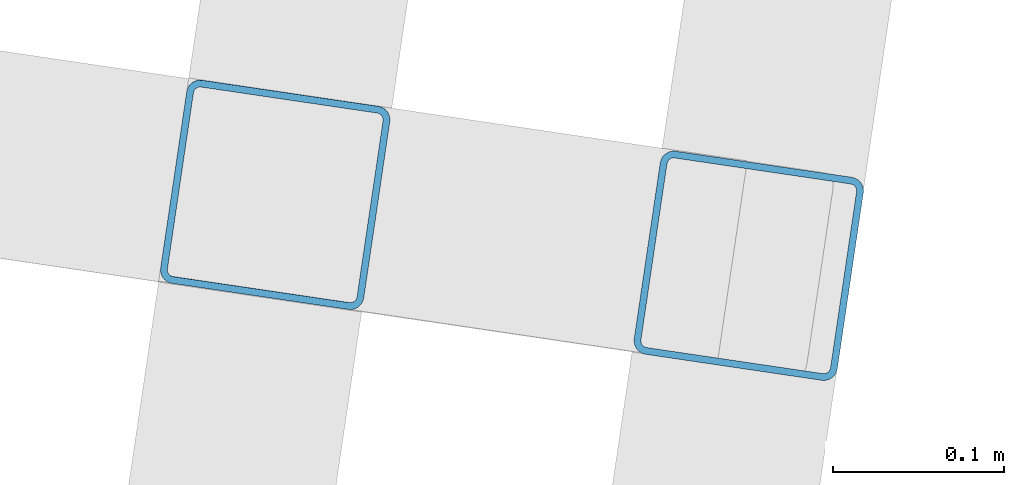
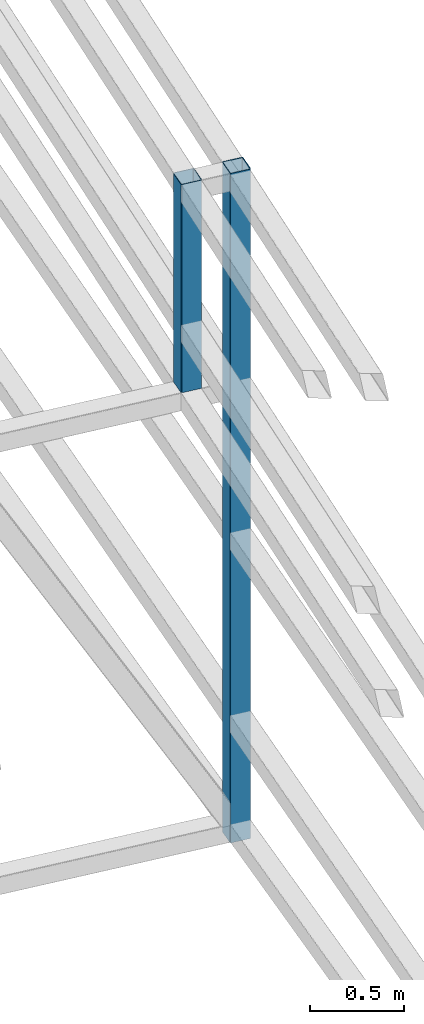
# One storey, part 120 of 215: 2 beams, 2 elements without a shape of their own.
"""IFC2X3 building model written with IfcOpenShell, lengths in millimetres."""

from ifc_helpers import new_model, si_unit, frame, origin_with_axes, origin_2d_with_axis, place, context, subcontext, project, spatial, hollow_rectangle, extrude, material, type_object, element, aggregate, save


model = new_model("IFC2X3")

# Units and contexts
model_context = context("Model", 3, precision=1e-05, world=origin_with_axes())
body_context = subcontext(model_context, "Body", "Model", "MODEL_VIEW")
ifc_project = project(units=[si_unit("LENGTHUNIT", "METRE", prefix="MILLI"), si_unit("AREAUNIT", "SQUARE_METRE"), si_unit("VOLUMEUNIT", "CUBIC_METRE"), si_unit("MASSUNIT", "GRAM", prefix="KILO"), si_unit("TIMEUNIT", "SECOND"), si_unit("PLANEANGLEUNIT", "RADIAN"), si_unit("SOLIDANGLEUNIT", "STERADIAN"), si_unit("THERMODYNAMICTEMPERATUREUNIT", "DEGREE_CELSIUS"), si_unit("LUMINOUSINTENSITYUNIT", "LUMEN")], contexts=[model_context])

# Site, building, storey
site_placement = place(None, origin_with_axes())
site = spatial("IfcSite", under=ifc_project, at=site_placement, CompositionType="ELEMENT")
building_placement = place(site_placement, origin_with_axes())
building = spatial("IfcBuilding", under=site, at=building_placement, Name="Undefined", CompositionType="ELEMENT")
storey_placement = place(building_placement, origin_with_axes())
storey = spatial("IfcBuildingStorey", under=building, at=storey_placement, Name="Undefined", CompositionType="ELEMENT", Elevation=0.0)

# Assembly, beam
assembly_1_placement = place(storey_placement, origin_with_axes())
assembly_1 = element("IfcElementAssembly", 1, at=assembly_1_placement, inside=storey, Name="Steel Assembly", AssemblyPlace="NOTDEFINED", PredefinedType="RIGID_FRAME")
ifc_material = material(Name="STEEL/S275JR")
beam_type = type_object("IfcBeamType", PredefinedType="NOTDEFINED")
beam_1_placement = place(assembly_1_placement, frame((151224.559046041, 48912.3710898929, 5008.70201033358), z_axis=(0.989259672851491, -0.146168736978062, 0.0), x_axis=(9.66599998929354e-06, 6.54179999871134e-05, -0.999999997813527)))
beam_1 = element("IfcBeam", 2, at=beam_1_placement, type_object=beam_type, material=ifc_material, Name="LISSE", context=body_context, shape_type="SweptSolid", body=[
    extrude(hollow_rectangle(XDim=120.0, YDim=120.0, WallThickness=4.0, InnerFilletRadius=4.0, OuterFilletRadius=8.0, at=origin_2d_with_axis()), frame((1349.81696449366, -1.45519152283669e-11, -2.91038315041901e-11), z_axis=(-1.0, 0.0, 0.0), x_axis=(-6.93889390390723e-18, -1.0, -3.46944695195361e-18)), (0.0, 0.0, 1.0), 1349.8),
])
aggregate(assembly_1, [beam_1])

assembly_2_placement = place(storey_placement, origin_with_axes())
assembly_2 = element("IfcElementAssembly", 3, at=assembly_2_placement, inside=storey, Name="Steel Assembly", AssemblyPlace="NOTDEFINED", PredefinedType="RIGID_FRAME")
beam_2_placement = place(assembly_2_placement, frame((151501.337584238, 48870.9236633127, 5008.70200526153), z_axis=(0.989259672851491, -0.146168736978062, 0.0), x_axis=(0.0, 0.0, -1.0)))
beam_2 = element("IfcBeam", 4, at=beam_2_placement, type_object=beam_type, material=ifc_material, Name="LISSE", context=body_context, shape_type="SweptSolid", body=[
    extrude(hollow_rectangle(XDim=120.0, YDim=120.0, WallThickness=4.0, InnerFilletRadius=4.0, OuterFilletRadius=8.0, at=origin_2d_with_axis()), frame((4339.32262234318, 0.0, 0.0), z_axis=(-1.0, 0.0, 0.0), x_axis=(-6.93889390390723e-18, -1.0, -3.46944695195361e-18)), (0.0, 0.0, 1.0), 4339.3),
])
aggregate(assembly_2, [beam_2])

save(model, "model.ifc")
